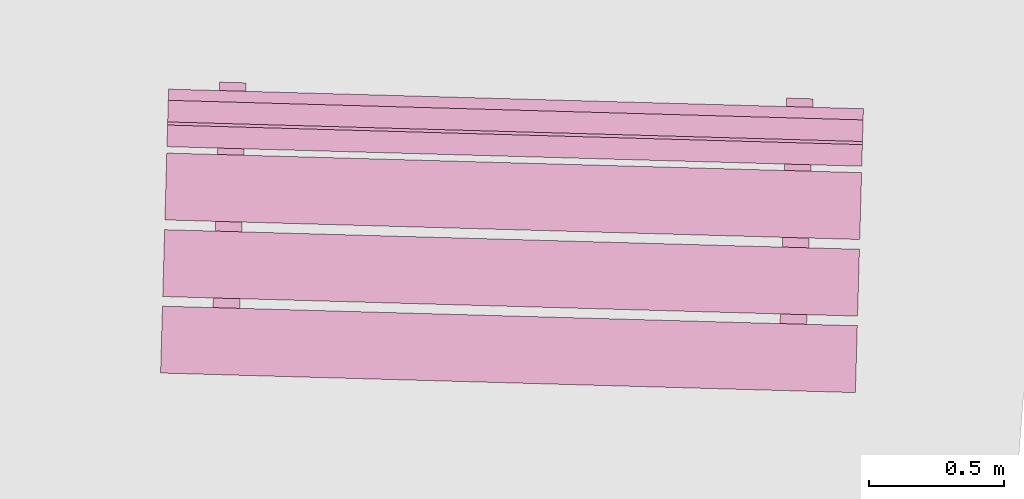
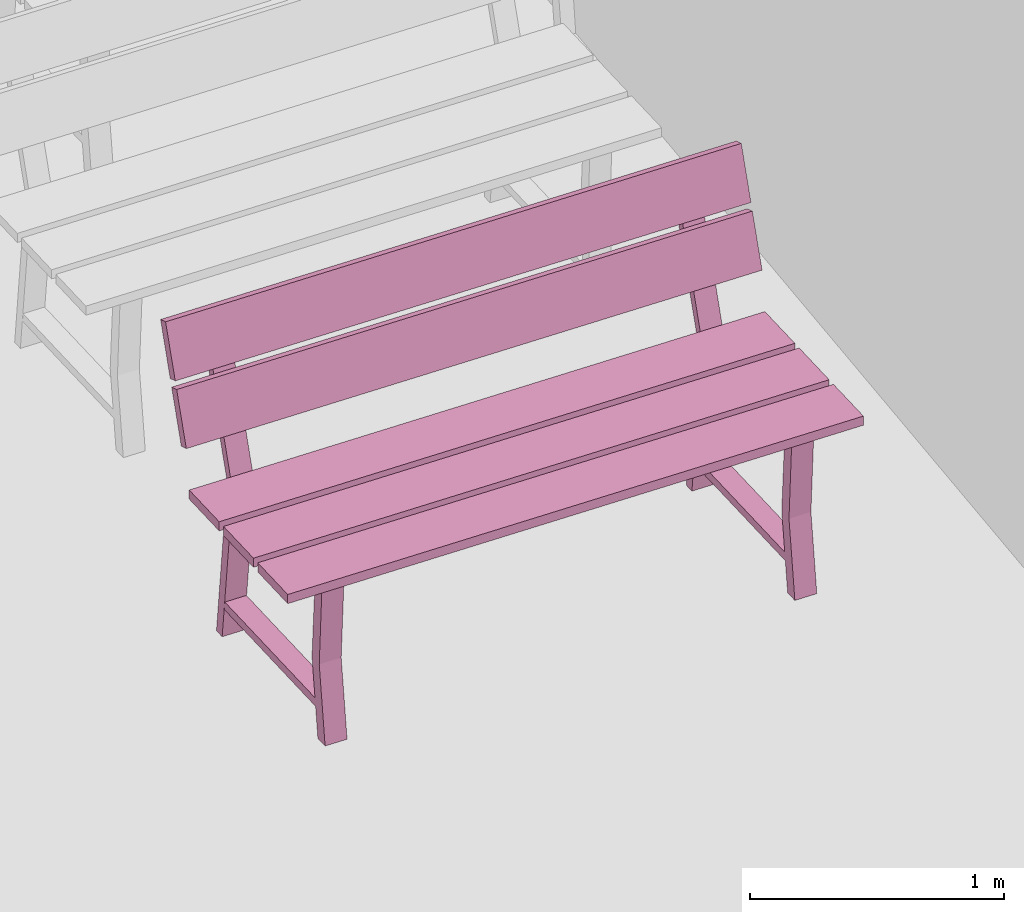
# One storey, part 18 of 200: 1 furnishing.
"""IFC4 building model written with IfcOpenShell, lengths in metres."""

from ifc_helpers import new_model, si_unit, origin_with_axes, place, context, subcontext, project, spatial, triangles, material, element, save


model = new_model("IFC4")

# Units and contexts
model_context = context("Model", 3, precision=1e-05, world=origin_with_axes())
body_context = subcontext(model_context, "Body", "Model", "MODEL_VIEW")
ifc_project = project(units=[si_unit("VOLUMEUNIT", "CUBIC_METRE"), si_unit("LENGTHUNIT", "METRE"), si_unit("AREAUNIT", "SQUARE_METRE")], contexts=[model_context])

# Site, building, storey
site_placement = place(None, origin_with_axes())
site = spatial("IfcSite", under=ifc_project, at=site_placement)
building_placement = place(site_placement, origin_with_axes())
building = spatial("IfcBuilding", under=site, at=building_placement, Name="Building")
storey_placement = place(building_placement, origin_with_axes())
storey = spatial("IfcBuildingStorey", under=building, at=storey_placement, Name="Ground")

# Furnishing
ifc_material = material(Name="bench")
furnishing_placement = place(storey_placement, origin_with_axes())
element("IfcFurnishingElement", 1, at=furnishing_placement, inside=storey, material=ifc_material, Name="cw_instances_bench_55", context=body_context, shape_type="Tessellation", body=[
    triangles([(238.05706123992906, -461.39293188370084, 0.8154595552323105), (238.06405468990292, -461.1447772072094, 0.8154595552323105), (235.48581601151506, -461.07211775354574, 0.8154595552323105), (235.47882256154122, -461.32027243003716, 0.8154595552323105), (235.6633753690531, -461.4622679215409, 0.3631407258093263), (235.76167346155867, -461.46503814051147, 0.3631407258093263), (235.7602974028192, -461.51386603126684, 1.4461350578594623e-07), (235.66199931031366, -461.5110958122962, 1.4461350578594623e-07), (235.75998507536357, -461.5249486184016, 0.3631407258093263), (235.6603154497178, -461.57084570440674, 1.606816730954958e-07), (235.75861354222337, -461.57361592337736, 1.606816730954958e-07), (235.66168698285804, -461.522178399431, 0.3631407258093263), (235.78145428868123, -460.76313782325917, 0.7741643170422662), (235.78145428868123, -460.76313782325917, 0.7741643170422662), (235.7839846011004, -460.6733525438699, 0.0), (235.68568650859484, -460.67058232489927, 0.0), (235.68568650859484, -460.67058232489927, 0.0), (235.68267435852792, -460.76035402522757, 0.7741643170422662), (235.7802547645243, -460.8057015836665, 0.7346366254607741), (235.684360241858, -460.71764340265776, 1.6068167309549576e-08), (235.78265833436356, -460.7204136216284, 1.6068167309549576e-08), (235.68195667201874, -460.8029313646959, 0.7352793682213234), (235.6626963947294, -461.4863605588341, 0.7352794646303272), (235.76098543422586, -461.4894520136111, 0.7346367218697779), (235.75928346942246, -461.54984431308725, 0.7741644616557719), (235.66050353926911, -461.54706051505565, 0.7741644616557719), (238.04906290685165, -461.676743702577, 0.8154596516413144), (238.05605635637284, -461.4285890421474, 0.8154595552323105), (235.477817677985, -461.3559295884837, 0.8154595552323105), (235.47082422846378, -461.60408424891335, 0.8154596516413144), (238.0650731534254, -461.1086381789915, 0.8154595552323105), (238.07206660294662, -460.86048351856186, 0.8154594588233067), (235.49382792455876, -460.78782406489825, 0.8154594588233067), (235.48683447503757, -461.0359787253278, 0.8154595552323105), (238.07273652607185, -460.83671205282786, 0.9999220838096051), (235.49675657526228, -460.6839042012249, 1.234838593466216), (235.494497847684, -460.7640525991642, 0.9999220838096051), (238.07499525365012, -460.75656365488857, 1.234838593466216), (238.07532116243, -460.744999149797, 1.2690638219718915), (235.49934121071513, -460.59219133031763, 1.5039802352194984), (235.49708248404215, -460.67233969613335, 1.2690638219718915), (238.07757988910296, -460.6648507839813, 1.5039802352194984), (235.68964045708344, -460.52457591468584, 1.4583467364693816), (235.78793864595974, -460.52734613637233, 1.4583467364693816), (235.78145428868123, -460.76313782325917, 0.7741643170422662), (235.68267435852792, -460.76035402522757, 0.7741643170422662), (235.68207436158957, -460.79875528315114, 0.7738429536960751), (235.7803860331561, -460.801043664474, 0.7738429536960751), (235.7868658643827, -460.56541257942854, 1.4723259616878532), (235.68855409644542, -460.56312419538983, 1.4723259616878532), (235.49567021281368, -460.72245254617604, 0.9857820483726994), (235.49792441434008, -460.6424647500781, 1.2206986544383143), (238.0739088912015, -460.79511199983966, 0.9857820483726994), (238.0761630927279, -460.71512420374177, 1.2206986544383143), (235.49825484871917, -460.630739659207, 1.2549238829439897), (235.5005135758448, -460.55059127732943, 1.4898404890096046), (238.076493527107, -460.7033991128706, 1.2549238829439897), (238.07875225423263, -460.6232507309931, 1.4898404890096046), (237.76698806320348, -461.5215515520124, 0.3631407258093263), (237.86528615570904, -461.524321770983, 0.3631407258093263), (237.86391009696956, -461.57314966173834, 1.4461350578594623e-07), (237.76561200446403, -461.5703794427677, 1.4461350578594623e-07), (237.86359776951394, -461.58423224887315, 0.3631407258093263), (237.76392814386818, -461.63012933487823, 1.606816730954958e-07), (237.86222623637374, -461.63289955384886, 1.606816730954958e-07), (237.76529967700841, -461.5814620299025, 0.3631407258093263), (237.8850669828316, -460.8224214537307, 0.7741643170422662), (237.8850669828316, -460.8224214537307, 0.7741643170422662), (237.88759729525077, -460.73263617434145, 0.0), (237.7892992027452, -460.7298659553708, 0.0), (237.7892992027452, -460.7298659553708, 0.0), (237.78644760633432, -460.81964218039303, 0.7741643170422662), (237.88386745867467, -460.864985214138, 0.7346366254607741), (237.78797293600837, -460.77692703312925, 1.6068167309549576e-08), (237.88627102851393, -460.7796972520999, 1.6068167309549576e-08), (237.78556936616914, -460.8622149951674, 0.7352793682213234), (237.76630908887978, -461.5456441893056, 0.7352794646303272), (237.86459812837623, -461.5487356440826, 0.7346367218697779), (237.86289616357283, -461.60912794355875, 0.7741644616557719), (237.76427678707552, -461.6063486702211, 0.7741644616557719), (237.79341380126058, -460.58386407256717, 1.4583467364693816), (237.8915513561719, -460.58662976729653, 1.4583467364693816), (237.8850669828316, -460.8224214537307, 0.7741643170422662), (237.78644760633432, -460.81964218039303, 0.7741643170422662), (237.78568705573994, -460.8580389136227, 0.7738429536960751), (237.88399872730648, -460.8603272949455, 0.7738429536960751), (237.89047857459485, -460.6246962103527, 1.4723259616878532), (237.79232744062256, -460.62241235327116, 1.4723259616878532), (238.06405468990292, -461.1447772072094, 0.8154595552323105), (235.48581601151506, -461.07211775354574, 0.7715934584772401), (235.48581601151506, -461.07211775354574, 0.8154595552323105), (238.06405468990292, -461.1447772072094, 0.7715934584772401), (238.05706123992906, -461.39293188370084, 0.771593506681742), (235.47882256154122, -461.32027243003716, 0.8154595552323105), (235.47882256154122, -461.32027243003716, 0.771593506681742), (238.05706123992906, -461.39293188370084, 0.8154595552323105), (235.66199931031366, -461.5110958122962, 1.4461350578594623e-07), (235.66168698285804, -461.522178399431, 0.3631407258093263), (235.6633753690531, -461.4622679215409, 0.3631407258093263), (235.6603154497178, -461.57084570440674, 1.606816730954958e-07), (235.68195667201874, -460.8029313646959, 0.7352793682213234), (235.68267435852792, -460.76035402522757, 0.7741643170422662), (235.68568650859484, -460.67058232489927, 0.0), (235.684360241858, -460.71764340265776, 1.6068167309549576e-08), (235.75998507536357, -461.5249486184016, 0.3631407258093263), (235.76167346155867, -461.46503814051147, 0.3631407258093263), (235.76098543422586, -461.4894520136111, 0.7346367218697779), (235.75928346942246, -461.54984431308725, 0.7741644616557719), (235.78145428868123, -460.76313782325917, 0.7741643170422662), (235.7802547645243, -460.8057015836665, 0.7346366254607741), (235.7839846011004, -460.6733525438699, 0.0), (235.78265833436356, -460.7204136216284, 1.6068167309549576e-08), (235.6626963947294, -461.4863605588341, 0.7352794646303272), (235.66050353926911, -461.54706051505565, 0.7741644616557719), (235.7602974028192, -461.51386603126684, 1.4461350578594623e-07), (235.75861354222337, -461.57361592337736, 1.606816730954958e-07), (235.68964045708344, -460.52457591468584, 1.4583467364693816), (235.7868658643827, -460.56541257942854, 1.4723259616878532), (235.78793864595974, -460.52734613637233, 1.4583467364693816), (235.68855409644542, -460.56312419538983, 1.4723259616878532), (235.78121715462842, -460.73162515719633, 0.13995373726617685), (235.78121715462842, -460.73162515719633, 0.17948142884766885), (235.75940845618584, -461.50548219870734, 0.13995388187968263), (235.75939487621955, -461.5059640684787, 0.1794815734611746), (235.684846412714, -460.7289092544696, 0.17948142884766885), (235.68516769670575, -460.7289183088367, 0.14059646395855885), (235.6633680508196, -461.5024541306031, 0.14059660857206463), (235.66302413430512, -461.503248165752, 0.1794815734611746), (238.05605635637284, -461.4285890421474, 0.8154595552323105), (235.477817677985, -461.3559295884837, 0.771593506681742), (235.477817677985, -461.3559295884837, 0.8154595552323105), (238.05605635637284, -461.4285890421474, 0.771593506681742), (238.04906290685165, -461.676743702577, 0.7715935548862439), (235.47082422846378, -461.60408424891335, 0.8154596516413144), (235.47082422846378, -461.60408424891335, 0.7715935548862439), (238.04906290685165, -461.676743702577, 0.8154596516413144), (238.07206660294662, -460.86048351856186, 0.8154594588233067), (235.49382792455876, -460.78782406489825, 0.7715934102727381), (235.49382792455876, -460.78782406489825, 0.8154594588233067), (238.07206660294662, -460.86048351856186, 0.7715934102727381), (238.06507315297276, -461.1086381950533, 0.7715934584772401), (235.48683447503757, -461.0359787253278, 0.8154595552323105), (235.48683447458492, -461.0359787413896, 0.7715934584772401), (238.0650731534254, -461.1086381789915, 0.8154595552323105), (235.49792441434008, -460.6424647500781, 1.2206986544383143), (238.07499525365012, -460.75656365488857, 1.234838593466216), (238.0761630927279, -460.71512420374177, 1.2206986544383143), (235.49675657526228, -460.6839042012249, 1.234838593466216), (238.0739088912015, -460.79511199983966, 0.9857820483726994), (235.494497847684, -460.7640525991642, 0.9999220838096051), (235.49567021281368, -460.72245254617604, 0.9857820483726994), (238.07273652607185, -460.83671205282786, 0.9999220838096051), (235.5005135758448, -460.55059127732943, 1.4898404890096046), (238.07757988910296, -460.6648507839813, 1.5039802352194984), (238.07875225423263, -460.6232507309931, 1.4898404890096046), (235.49934121071513, -460.59219133031763, 1.5039802352194984), (238.076493527107, -460.7033991128706, 1.2549238829439897), (235.49708248404215, -460.67233969613335, 1.2690638219718915), (235.49825484871917, -460.630739659207, 1.2549238829439897), (238.07532116243, -460.744999149797, 1.2690638219718915), (237.76561200446403, -461.5703794427677, 1.4461350578594623e-07), (237.76529967700841, -461.5814620299025, 0.3631407258093263), (237.76698806320348, -461.5215515520124, 0.3631407258093263), (237.76392814386818, -461.63012933487823, 1.606816730954958e-07), (237.78556936616914, -460.8622149951674, 0.7352793682213234), (237.78644760633432, -460.81964218039303, 0.7741643170422662), (237.7892992027452, -460.7298659553708, 0.0), (237.78797293600837, -460.77692703312925, 1.6068167309549576e-08), (237.86359776951394, -461.58423224887315, 0.3631407258093263), (237.86528615570904, -461.524321770983, 0.3631407258093263), (237.86459812837623, -461.5487356440826, 0.7346367218697779), (237.86289616357283, -461.60912794355875, 0.7741644616557719), (237.8850669828316, -460.8224214537307, 0.7741643170422662), (237.88386745867467, -460.864985214138, 0.7346366254607741), (237.88759729525077, -460.73263617434145, 0.0), (237.88627102851393, -460.7796972520999, 1.6068167309549576e-08), (237.76630908887978, -461.5456441893056, 0.7352794646303272), (237.76427678707552, -461.6063486702211, 0.7741644616557719), (237.86391009696956, -461.57314966173834, 1.4461350578594623e-07), (237.86222623637374, -461.63289955384886, 1.606816730954958e-07), (237.79341380126058, -460.58386407256717, 1.4583467364693816), (237.89047857459485, -460.6246962103527, 1.4723259616878532), (237.8915513561719, -460.58662976729653, 1.4583467364693816), (237.79232744062256, -460.62241235327116, 1.4723259616878532), (237.88499049880556, -460.79091331507766, 0.13995373726617685), (237.88499049880556, -460.79091331507766, 0.17948142884766885), (237.86318180036298, -461.56477035658867, 0.13995388187968263), (237.8631682203967, -461.56525222636003, 0.1794815734611746), (237.78845910686437, -460.78819288494117, 0.17948142884766885), (237.78894094451215, -460.78820646400214, 0.14059646395855885), (237.767141298626, -461.56174228576856, 0.14059660857206463), (237.7666368284555, -461.56253179622354, 0.1794815734611746), (238.05706123992906, -461.39293188370084, 0.8154595552323105), (238.06405468990292, -461.1447772072094, 0.7715934584772401), (238.06405468990292, -461.1447772072094, 0.8154595552323105), (238.05706123992906, -461.39293188370084, 0.771593506681742), (235.48581601151506, -461.07211775354574, 0.8154595552323105), (235.48581601151506, -461.07211775354574, 0.7715934584772401), (235.47882256154122, -461.32027243003716, 0.771593506681742), (235.47882256154122, -461.32027243003716, 0.8154595552323105), (238.04906290685165, -461.676743702577, 0.8154596516413144), (238.05605635637284, -461.4285890421474, 0.771593506681742), (238.05605635637284, -461.4285890421474, 0.8154595552323105), (238.04906290685165, -461.676743702577, 0.7715935548862439), (235.477817677985, -461.3559295884837, 0.8154595552323105), (235.477817677985, -461.3559295884837, 0.771593506681742), (235.47082422846378, -461.60408424891335, 0.7715935548862439), (235.47082422846378, -461.60408424891335, 0.8154596516413144), (238.0650731534254, -461.1086381789915, 0.8154595552323105), (238.07206660294662, -460.86048351856186, 0.7715934102727381), (238.07206660294662, -460.86048351856186, 0.8154594588233067), (238.06507315297276, -461.1086381950533, 0.7715934584772401), (235.49382792455876, -460.78782406489825, 0.8154594588233067), (235.49382792455876, -460.78782406489825, 0.7715934102727381), (235.48683447458492, -461.0359787413896, 0.7715934584772401), (235.48683447503757, -461.0359787253278, 0.8154595552323105), (238.0739088912015, -460.79511199983966, 0.9857820483726994), (238.0761630927279, -460.71512420374177, 1.2206986544383143), (238.07499525365012, -460.75656365488857, 1.234838593466216), (238.07273652607185, -460.83671205282786, 0.9999220838096051), (235.49675657526228, -460.6839042012249, 1.234838593466216), (235.49567021281368, -460.72245254617604, 0.9857820483726994), (235.494497847684, -460.7640525991642, 0.9999220838096051), (235.49792441434008, -460.6424647500781, 1.2206986544383143), (238.076493527107, -460.7033991128706, 1.2549238829439897), (238.07875225423263, -460.6232507309931, 1.4898404890096046), (238.07757988910296, -460.6648507839813, 1.5039802352194984), (238.07532116243, -460.744999149797, 1.2690638219718915), (235.49934121071513, -460.59219133031763, 1.5039802352194984), (235.49825484871917, -460.630739659207, 1.2549238829439897), (235.49708248404215, -460.67233969613335, 1.2690638219718915), (235.5005135758448, -460.55059127732943, 1.4898404890096046), (235.7803860331561, -460.801043664474, 0.7738429536960751), (235.7868658643827, -460.56541257942854, 1.4723259616878532), (235.78793864595974, -460.52734613637233, 1.4583467364693816), (235.68267435852792, -460.76035402522757, 0.7741643170422662), (235.68207436158957, -460.79875528315114, 0.7738429536960751), (235.68855409644542, -460.56312419538983, 1.4723259616878532), (235.68964045708344, -460.52457591468584, 1.4583467364693816), (237.88399872730648, -460.8603272949455, 0.7738429536960751), (237.89047857459485, -460.6246962103527, 1.4723259616878532), (237.8915513561719, -460.58662976729653, 1.4583467364693816), (237.78644760633432, -460.81964218039303, 0.7741643170422662), (237.78568705573994, -460.8580389136227, 0.7738429536960751), (237.79232744062256, -460.62241235327116, 1.4723259616878532), (237.79341380126058, -460.58386407256717, 1.4583467364693816), (235.78145428868123, -460.76313782325917, 0.7741643170422662), (235.68267435852792, -460.76035402522757, 0.7741643170422662), (235.75928346942246, -461.54984431308725, 0.7741644616557719), (235.66050353926911, -461.54706051505565, 0.7741644616557719), (235.78121715462842, -460.73162515719633, 0.17948142884766885), (235.684846412714, -460.7289092544696, 0.17948142884766885), (235.75939487621955, -461.5059640684787, 0.1794815734611746), (235.66302413430512, -461.503248165752, 0.1794815734611746), (237.8850669828316, -460.8224214537307, 0.7741643170422662), (237.78644760633432, -460.81964218039303, 0.7741643170422662), (237.86289616357283, -461.60912794355875, 0.7741644616557719), (237.76427678707552, -461.6063486702211, 0.7741644616557719), (237.88499049880556, -460.79091331507766, 0.17948142884766885), (237.78845910686437, -460.78819288494117, 0.17948142884766885), (237.8631682203967, -461.56525222636003, 0.1794815734611746), (237.7666368284555, -461.56253179622354, 0.1794815734611746)], [[1, 2, 3], [3, 4, 1], [5, 6, 7], [7, 8, 5], [9, 10, 11], [10, 9, 12], [14, 15, 16], [17, 18, 13], [19, 20, 21], [20, 19, 22], [23, 24, 5], [24, 6, 5], [12, 9, 25], [25, 26, 12], [27, 28, 29], [29, 30, 27], [31, 32, 33], [33, 34, 31], [35, 36, 37], [35, 38, 36], [39, 40, 41], [39, 42, 40], [43, 44, 45], [45, 46, 43], [47, 48, 49], [49, 50, 47], [51, 52, 53], [54, 53, 52], [55, 56, 57], [58, 57, 56], [59, 60, 61], [61, 62, 59], [63, 64, 65], [64, 63, 66], [68, 69, 71], [70, 72, 67], [73, 74, 75], [74, 73, 76], [77, 78, 59], [78, 60, 59], [66, 63, 79], [79, 80, 66], [81, 82, 83], [83, 84, 81], [85, 86, 87], [87, 88, 85], [89, 90, 91], [89, 92, 90], [93, 94, 95], [93, 96, 94], [97, 98, 99], [97, 100, 98], [101, 102, 103], [103, 104, 101], [105, 106, 107], [107, 108, 105], [109, 110, 111], [110, 112, 111], [108, 107, 109], [107, 110, 109], [113, 99, 98], [98, 114, 113], [115, 106, 105], [105, 116, 115], [117, 118, 119], [117, 120, 118], [102, 101, 113], [113, 114, 102], [121, 122, 123], [122, 124, 123], [125, 126, 127], [127, 128, 125], [129, 130, 131], [129, 132, 130], [133, 134, 135], [133, 136, 134], [137, 138, 139], [137, 140, 138], [141, 142, 143], [141, 144, 142], [145, 146, 147], [145, 148, 146], [149, 150, 151], [149, 152, 150], [153, 154, 155], [153, 156, 154], [157, 158, 159], [157, 160, 158], [161, 162, 163], [161, 164, 162], [165, 166, 167], [167, 168, 165], [169, 170, 171], [171, 172, 169], [173, 174, 175], [174, 176, 175], [172, 171, 173], [171, 174, 173], [177, 163, 162], [162, 178, 177], [179, 170, 169], [169, 180, 179], [181, 182, 183], [181, 184, 182], [166, 165, 177], [177, 178, 166], [185, 186, 187], [186, 188, 187], [189, 190, 191], [191, 192, 189], [193, 194, 195], [194, 193, 196], [197, 198, 199], [199, 200, 197], [201, 202, 203], [202, 201, 204], [205, 206, 207], [207, 208, 205], [209, 210, 211], [210, 209, 212], [213, 214, 215], [215, 216, 213], [217, 218, 219], [219, 220, 217], [221, 222, 223], [222, 221, 224], [225, 226, 227], [227, 228, 225], [229, 230, 231], [230, 229, 232], [233, 109, 234], [109, 235, 234], [236, 237, 238], [238, 239, 236], [240, 173, 241], [173, 242, 241], [243, 244, 245], [245, 246, 243], [247, 248, 249], [248, 250, 249], [251, 252, 253], [252, 254, 253], [255, 256, 257], [256, 258, 257], [259, 260, 261], [260, 262, 261]], closed=True),
])

save(model, "model.ifc")
